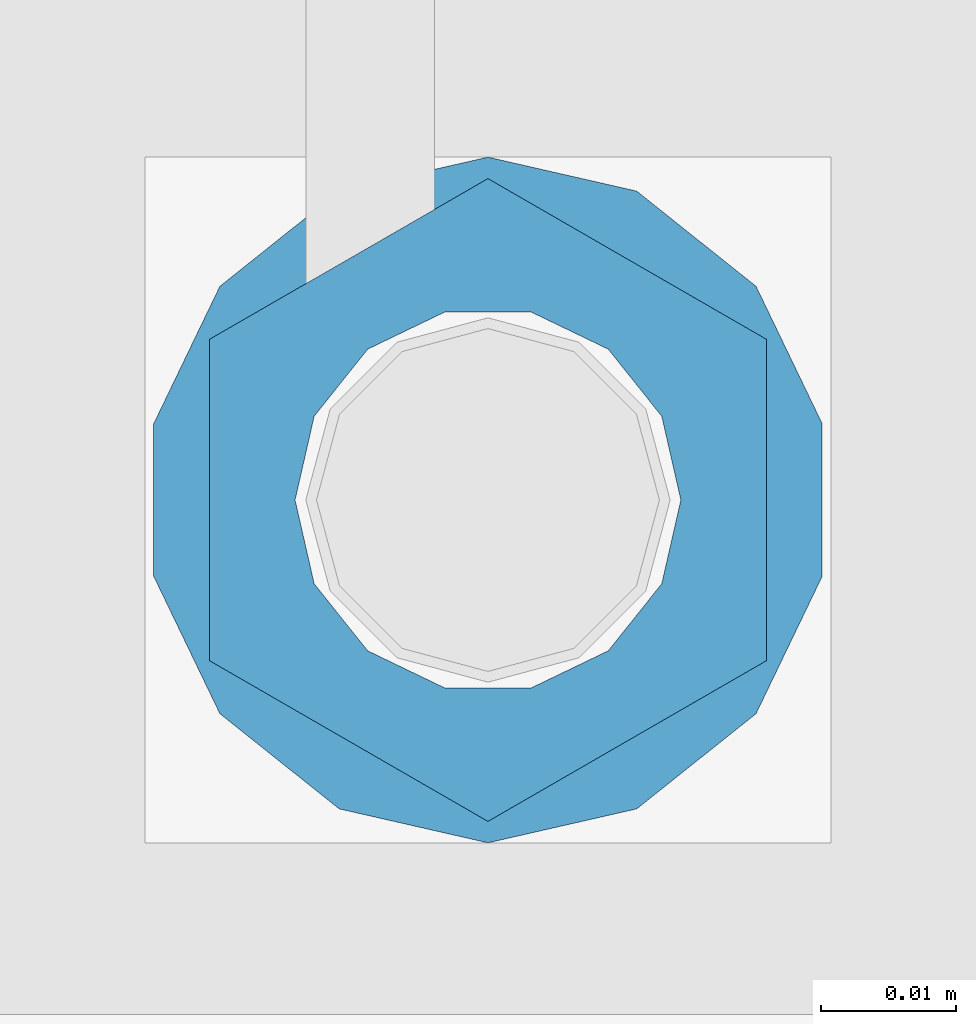
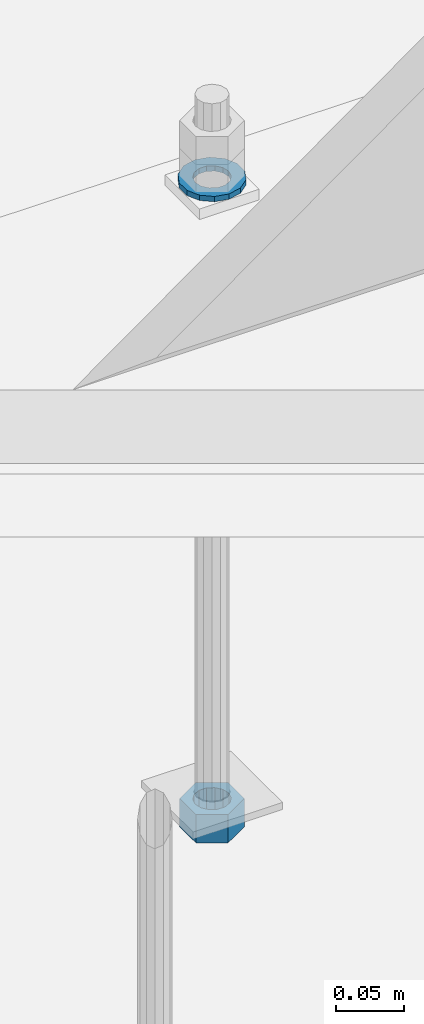
# One storey, part 1030 of 1763: 2 columns, 1 element without a shape of its own.
"""IFC2X3 building model written with IfcOpenShell, lengths in millimetres."""

from ifc_helpers import new_model, si_unit, frame, origin_with_axes, place, context, subcontext, project, spatial, faceted_brep, material, type_object, element, aggregate, save


model = new_model("IFC2X3")

# Units and contexts
model_context = context("Model", 3, precision=1e-05, world=origin_with_axes())
body_context = subcontext(model_context, "Body", "Model", "MODEL_VIEW")
ifc_project = project(units=[si_unit("LENGTHUNIT", "METRE", prefix="MILLI"), si_unit("AREAUNIT", "SQUARE_METRE"), si_unit("VOLUMEUNIT", "CUBIC_METRE"), si_unit("MASSUNIT", "GRAM", prefix="KILO"), si_unit("TIMEUNIT", "SECOND"), si_unit("PLANEANGLEUNIT", "RADIAN"), si_unit("SOLIDANGLEUNIT", "STERADIAN"), si_unit("THERMODYNAMICTEMPERATUREUNIT", "DEGREE_CELSIUS"), si_unit("LUMINOUSINTENSITYUNIT", "LUMEN")], contexts=[model_context])

# Site, building, storey
site_placement = place(None, origin_with_axes())
site = spatial("IfcSite", under=ifc_project, at=site_placement, CompositionType="ELEMENT")
building_placement = place(site_placement, origin_with_axes())
building = spatial("IfcBuilding", under=site, at=building_placement, Name="Undefined", CompositionType="ELEMENT")
storey_placement = place(building_placement, origin_with_axes())
storey = spatial("IfcBuildingStorey", under=building, at=storey_placement, Name="Undefined", CompositionType="ELEMENT", Elevation=0.0)

# Assembly, columns
assembly_placement = place(storey_placement, origin_with_axes())
assembly = element("IfcElementAssembly", 1, at=assembly_placement, inside=storey, Name="TEMPLATE", AssemblyPlace="NOTDEFINED", PredefinedType="RIGID_FRAME")
ifc_material_1 = material(Name="STEEL/A563")
column_type_1 = type_object("IfcColumnType", Name="1_HEAVY_HEX_NUT", PredefinedType="NOTDEFINED")
column_1_placement = place(assembly_placement, frame((-34949.8372736984, 52298.6, -761.999999999998), z_axis=(-1.0, 0.0, 0.0), x_axis=(0.0, 0.0, -1.0)))
column_1 = element("IfcColumn", 2, at=column_1_placement, type_object=column_type_1, material=ifc_material_1, Name="NUT", ObjectType="1_HEAVY_HEX_NUT", context=body_context, shape_type="Brep", body=[
    faceted_brep([(0.0, -23.8099994659424, 0.0), (0.0, -11.9099998474121, -20.6200008392334), (25.4, -11.9099998474121, -20.6200008392334), (25.4, -23.8099994659424, 0.0), (0.0, 11.9099998474121, -20.6200008392334), (25.4, 11.9099998474121, -20.6200008392334), (0.0, 23.8099994659424, 0.0), (25.4, 23.8099994659424, 0.0), (0.0, 11.9099998474121, 20.6200008392334), (25.4, 11.9099998474121, 20.6200008392334), (0.0, -11.9099998474121, 20.6200008392334), (25.4, -11.9099998474121, 20.6200008392334), (0.0, 0.0, 14.289999961853), (0.0, 6.20019861543551, 12.8748450879575), (25.4, 6.20019861543551, 12.8748450879502), (25.4, 0.0, 14.289999961853), (0.0, 11.1723718546418, 8.90966924477834), (25.4, 11.1723718546418, 8.90966924477834), (0.0, 13.9317198278877, 3.17982413774735), (25.4, 13.9317198278877, 3.17982413774007), (0.0, 13.9317198278877, -3.17982413774735), (25.4, 13.9317198278877, -3.17982413774007), (0.0, 11.1723718546418, -8.90966924477834), (25.4, 11.1723718546418, -8.90966924477834), (0.0, 6.20019861543551, -12.8748450879575), (25.4, 6.20019861543551, -12.8748450879502), (0.0, 0.0, -14.289999961853), (25.4, 0.0, -14.289999961853), (0.0, -6.20019861543551, -12.8748450879575), (25.4, -6.20019861543551, -12.8748450879502), (0.0, -11.1723718546418, -8.90966924477834), (25.4, -11.1723718546418, -8.90966924477834), (0.0, -13.9317198278877, -3.17982413774735), (25.4, -13.9317198278877, -3.17982413774007), (0.0, -13.9317198278877, 3.17982413774735), (25.4, -13.9317198278877, 3.17982413774007), (0.0, -11.1723718546418, 8.90966924477834), (25.4, -11.1723718546418, 8.90966924477834), (0.0, -6.20019861543551, 12.8748450879575), (25.4, -6.20019861543551, 12.8748450879502)], [[[0, 1, 2, 3]], [[1, 4, 5, 2]], [[4, 6, 7, 5]], [[6, 8, 9, 7]], [[8, 10, 11, 9]], [[10, 0, 3, 11]], [[12, 13, 14, 15]], [[13, 16, 17, 14]], [[16, 18, 19, 17]], [[18, 20, 21, 19]], [[20, 22, 23, 21]], [[22, 24, 25, 23]], [[24, 26, 27, 25]], [[26, 28, 29, 27]], [[28, 30, 31, 29]], [[30, 32, 33, 31]], [[32, 34, 35, 33]], [[34, 36, 37, 35]], [[36, 38, 39, 37]], [[38, 12, 15, 39]], [[5, 7, 9, 11, 3, 2], [17, 19, 21, 23, 25, 27, 29, 31, 33, 35, 37, 39, 15, 14]], [[10, 8, 6, 4, 1, 0], [38, 36, 34, 32, 30, 28, 26, 24, 22, 20, 18, 16, 13, 12]]]),
])
ifc_material_2 = material(Name="STEEL/F436")
column_type_2 = type_object("IfcColumnType", Name="1_WASHER", PredefinedType="NOTDEFINED")
column_2_placement = place(assembly_placement, frame((-34949.8372736984, 52298.6, -201.612499999997), z_axis=(-1.0, 0.0, 0.0), x_axis=(0.0, 0.0, -1.0)))
column_2 = element("IfcColumn", 3, at=column_2_placement, type_object=column_type_2, material=ifc_material_2, Name="WASHER", ObjectType="1_WASHER", context=body_context, shape_type="Brep", body=[
    faceted_brep([(0.0, -25.4000000000015, 0.0), (0.0, -22.8846089010258, -11.0206468080723), (4.76249999999982, -22.8846089010258, -11.0206468080723), (4.76249999999982, -25.3999996185303, 0.0), (0.0, -15.8366407293724, -19.8585193564359), (4.76249999999982, -15.8366407293724, -19.8585193564359), (0.0, -5.65203163760452, -24.7631685975066), (4.76249999999982, -5.65203163760452, -24.7631685975066), (0.0, 5.65203163760452, -24.7631685975066), (4.76249999999982, 5.65203163760452, -24.7631685975066), (0.0, 15.8366407293724, -19.8585193564359), (4.76249999999982, 15.8366407293724, -19.8585193564359), (0.0, 22.8846089010258, -11.0206468080723), (4.76249999999982, 22.8846089010258, -11.0206468080723), (0.0, 25.4000000000015, 0.0), (4.76249999999982, 25.3999996185303, 0.0), (0.0, 22.8846089010258, 11.0206468080723), (4.76249999999982, 22.8846089010258, 11.0206468080723), (0.0, 15.8366407293724, 19.8585193564359), (4.76249999999982, 15.8366407293724, 19.8585193564359), (0.0, 5.65203163760452, 24.7631685975066), (4.76249999999982, 5.65203163760452, 24.7631685975066), (0.0, -5.65203163760452, 24.7631685975066), (4.76249999999982, -5.65203163760452, 24.7631685975066), (0.0, -15.8366407293724, 19.8585193564359), (4.76249999999982, -15.8366407293724, 19.8585193564359), (0.0, -22.8846089010258, 11.0206468080723), (4.76249999999982, -22.8846089010258, 11.0206468080723), (0.0, 0.0, 14.289999961853), (0.0, 6.20019861543551, 12.8748450879575), (4.76249999999982, 6.20019861543551, 12.8748450879502), (4.76249999999982, 0.0, 14.289999961853), (0.0, 11.1723718546418, 8.90966924477834), (4.76249999999982, 11.1723718546418, 8.90966924477834), (0.0, 13.9317198278877, 3.17982413774735), (4.76249999999982, 13.9317198278877, 3.17982413774007), (0.0, 13.9317198278877, -3.17982413774735), (4.76249999999982, 13.9317198278877, -3.17982413774007), (0.0, 11.1723718546418, -8.90966924477834), (4.76249999999982, 11.1723718546418, -8.90966924477834), (0.0, 6.20019861543551, -12.8748450879575), (4.76249999999982, 6.20019861543551, -12.8748450879502), (0.0, 0.0, -14.289999961853), (4.76249999999982, 0.0, -14.289999961853), (0.0, -6.20019861543551, -12.8748450879575), (4.76249999999982, -6.20019861543551, -12.8748450879502), (0.0, -11.1723718546418, -8.90966924477834), (4.76249999999982, -11.1723718546418, -8.90966924477834), (0.0, -13.9317198278877, -3.17982413774735), (4.76249999999982, -13.9317198278877, -3.17982413774007), (0.0, -13.9317198278877, 3.17982413774735), (4.76249999999982, -13.9317198278877, 3.17982413774007), (0.0, -11.1723718546418, 8.90966924477834), (4.76249999999982, -11.1723718546418, 8.90966924477834), (0.0, -6.20019861543551, 12.8748450879575), (4.76249999999982, -6.20019861543551, 12.8748450879502)], [[[0, 1, 2, 3]], [[1, 4, 5, 2]], [[4, 6, 7, 5]], [[6, 8, 9, 7]], [[8, 10, 11, 9]], [[10, 12, 13, 11]], [[12, 14, 15, 13]], [[14, 16, 17, 15]], [[16, 18, 19, 17]], [[18, 20, 21, 19]], [[20, 22, 23, 21]], [[22, 24, 25, 23]], [[24, 26, 27, 25]], [[26, 0, 3, 27]], [[28, 29, 30, 31]], [[29, 32, 33, 30]], [[32, 34, 35, 33]], [[34, 36, 37, 35]], [[36, 38, 39, 37]], [[38, 40, 41, 39]], [[40, 42, 43, 41]], [[42, 44, 45, 43]], [[44, 46, 47, 45]], [[46, 48, 49, 47]], [[48, 50, 51, 49]], [[50, 52, 53, 51]], [[52, 54, 55, 53]], [[54, 28, 31, 55]], [[5, 7, 9, 11, 13, 15, 17, 19, 21, 23, 25, 27, 3, 2], [33, 35, 37, 39, 41, 43, 45, 47, 49, 51, 53, 55, 31, 30]], [[26, 24, 22, 20, 18, 16, 14, 12, 10, 8, 6, 4, 1, 0], [54, 52, 50, 48, 46, 44, 42, 40, 38, 36, 34, 32, 29, 28]]]),
])
aggregate(assembly, [column_2, column_1])

save(model, "model.ifc")
